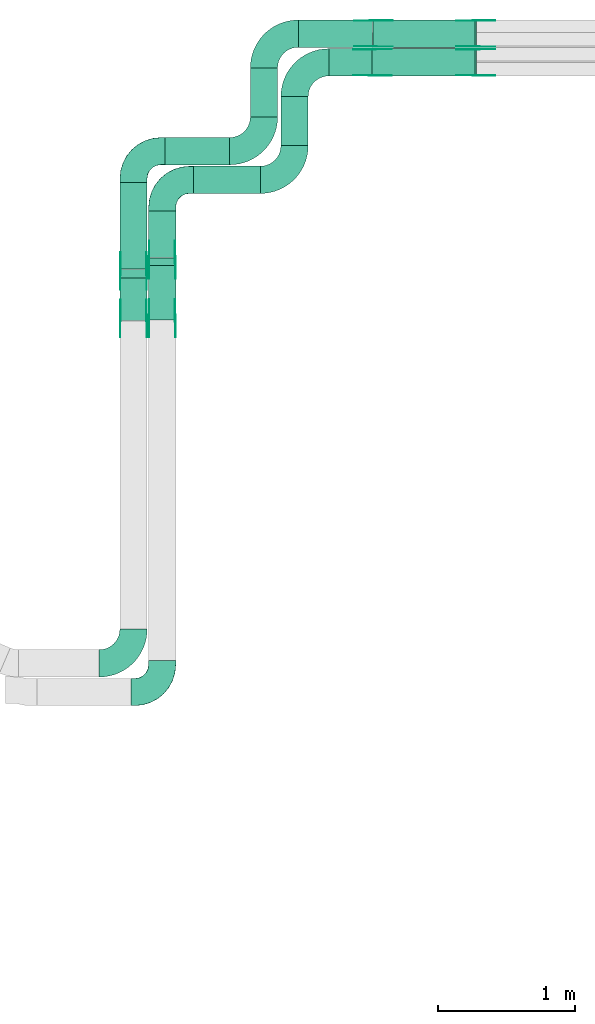
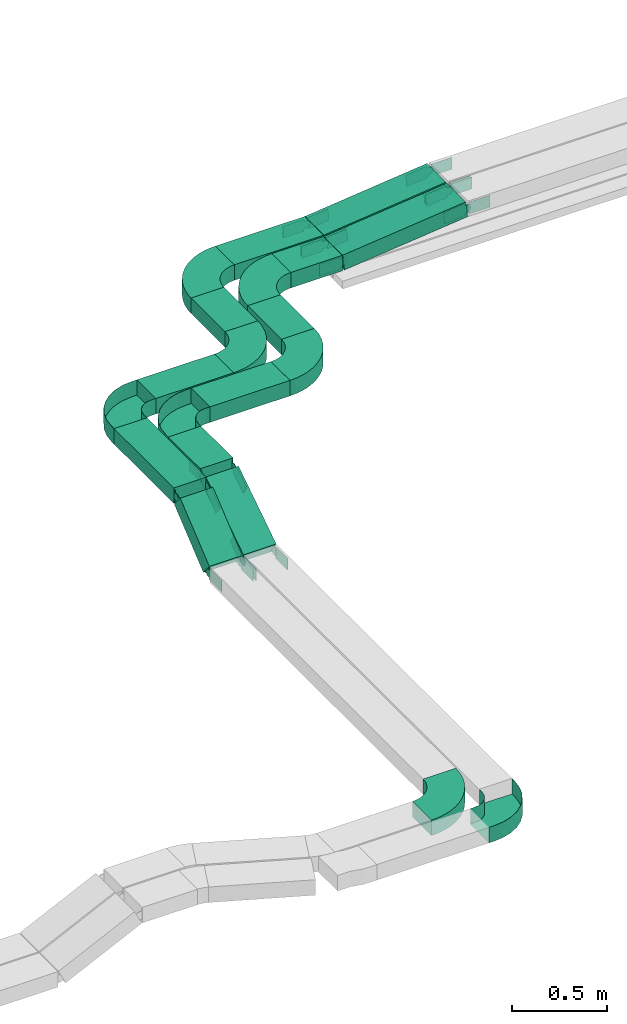
# One storey, part 16 of 25: 40 flow fittings, 12 flow segments.
"""IFC2X3 building model written with IfcOpenShell, lengths in millimetres."""

from ifc_helpers import new_model, entity, si_unit, converted_unit, derived_unit, direction, frame, frame_2d, origin, origin_2d_with_axis, place, context, subcontext, project, spatial, polyline, circle_curve, parameter, trimmed, segment, composite_curve, rectangle, outline, extrude, faceted_brep, source, transform, mapped, material, type_object, type_shapes, element, save


model = new_model("IFC2X3")

# Units and contexts
model_context = context("Model", 3, precision=0.01, world=origin(), true_north=direction((6.12303176911189e-17, 1.0)))
body_context = subcontext(model_context, "Body", "Model", "MODEL_VIEW")
ifc_project = project(units=[si_unit("LENGTHUNIT", "METRE", prefix="MILLI"), si_unit("AREAUNIT", "SQUARE_METRE"), si_unit("VOLUMEUNIT", "CUBIC_METRE"), converted_unit("PLANEANGLEUNIT", "DEGREE", entity("IfcRatioMeasure", 0.0174532925199433), si_unit("PLANEANGLEUNIT", "RADIAN"), dimensions=[0, 0, 0, 0, 0, 0, 0]), si_unit("MASSUNIT", "GRAM", prefix="KILO"), derived_unit("MASSDENSITYUNIT", [(si_unit("MASSUNIT", "GRAM", prefix="KILO"), 1), (si_unit("LENGTHUNIT", "METRE"), -3)]), derived_unit("MOMENTOFINERTIAUNIT", [(si_unit("LENGTHUNIT", "METRE"), 4)]), si_unit("TIMEUNIT", "SECOND"), si_unit("FREQUENCYUNIT", "HERTZ"), si_unit("THERMODYNAMICTEMPERATUREUNIT", "DEGREE_CELSIUS"), derived_unit("THERMALTRANSMITTANCEUNIT", [(si_unit("MASSUNIT", "GRAM", prefix="KILO"), 1), (si_unit("THERMODYNAMICTEMPERATUREUNIT", "KELVIN"), -1), (si_unit("TIMEUNIT", "SECOND"), -3)]), derived_unit("VOLUMETRICFLOWRATEUNIT", [(si_unit("LENGTHUNIT", "METRE"), 3), (si_unit("TIMEUNIT", "SECOND"), -1)]), derived_unit("MASSFLOWRATEUNIT", [(si_unit("MASSUNIT", "GRAM", prefix="KILO"), 1), (si_unit("TIMEUNIT", "SECOND"), -1)]), derived_unit("ROTATIONALFREQUENCYUNIT", [(si_unit("TIMEUNIT", "SECOND"), -1)]), si_unit("ELECTRICCURRENTUNIT", "AMPERE"), si_unit("ELECTRICVOLTAGEUNIT", "VOLT"), si_unit("POWERUNIT", "WATT"), si_unit("FORCEUNIT", "NEWTON", prefix="KILO"), si_unit("ILLUMINANCEUNIT", "LUX"), si_unit("LUMINOUSFLUXUNIT", "LUMEN"), si_unit("LUMINOUSINTENSITYUNIT", "CANDELA"), derived_unit("USERDEFINED", [(si_unit("MASSUNIT", "GRAM", prefix="KILO"), -1), (si_unit("LENGTHUNIT", "METRE"), -2), (si_unit("TIMEUNIT", "SECOND"), 3), (si_unit("LUMINOUSFLUXUNIT", "LUMEN"), 1)]), derived_unit("LINEARVELOCITYUNIT", [(si_unit("LENGTHUNIT", "METRE"), 1), (si_unit("TIMEUNIT", "SECOND"), -1)]), si_unit("PRESSUREUNIT", "PASCAL"), derived_unit("USERDEFINED", [(si_unit("LENGTHUNIT", "METRE"), -2), (si_unit("MASSUNIT", "GRAM", prefix="KILO"), 1), (si_unit("TIMEUNIT", "SECOND"), -2)]), derived_unit("LINEARFORCEUNIT", [(si_unit("MASSUNIT", "GRAM", prefix="KILO"), 1), (si_unit("LENGTHUNIT", "METRE"), 1), (si_unit("TIMEUNIT", "SECOND"), -2), (si_unit("LENGTHUNIT", "METRE"), -1)]), derived_unit("PLANARFORCEUNIT", [(si_unit("MASSUNIT", "GRAM", prefix="KILO"), 1), (si_unit("LENGTHUNIT", "METRE"), 1), (si_unit("TIMEUNIT", "SECOND"), -2), (si_unit("LENGTHUNIT", "METRE"), -2)])], contexts=[model_context])

# Site, building, storey
site_placement = place(None, frame((0.0, -0.00077364408347762, 0.0)))
site = spatial("IfcSite", under=ifc_project, at=site_placement, CompositionType="ELEMENT")
building_placement = place(site_placement, origin())
building = spatial("IfcBuilding", under=site, at=building_placement, CompositionType="ELEMENT")
storey_placement = place(building_placement, frame((0.0, 0.0, 24000.0)))
storey = spatial("IfcBuildingStorey", under=building, at=storey_placement, CompositionType="ELEMENT", Elevation=24000.0)

# Flow segments
cable_carrier_segment_type = type_object("IfcCableCarrierSegmentType", PredefinedType="CABLETRAYSEGMENT")
flow_segment_1_placement = place(storey_placement, frame((40330.6005282686, 17371.8034156188, 3163.62105725894)))
element("IfcFlowSegment", 1, at=flow_segment_1_placement, inside=storey, type_object=cable_carrier_segment_type, context=body_context, shape_type="SweptSolid", body=[
    extrude(rectangle(XDim=338.196584381319, YDim=200.000000000007, at=frame_2d((-1.08002495835535e-12, 4.33431068813661e-12), x_axis=(1.0, 0.0))), frame((100.0, 169.098292190666, 0.0), z_axis=(0.0, 0.0, 1.0), x_axis=(0.0, 1.0, 0.0)), (0.0, 0.0, 1.0), 99.9999999999989),
])
flow_segment_2_placement = place(storey_placement, frame((40120.6005282686, 17287.9524673424, 3163.62105725894)))
element("IfcFlowSegment", 2, at=flow_segment_2_placement, inside=storey, type_object=cable_carrier_segment_type, context=body_context, shape_type="SweptSolid", body=[
    extrude(rectangle(XDim=632.047532657661, YDim=200.000000000007, at=frame_2d((1.08002495835535e-12, 4.33431068813661e-12), x_axis=(1.0, 0.0))), frame((100.0, 316.023766328833, 0.0), z_axis=(0.0, 0.0, 1.0), x_axis=(0.0, -1.0, 0.0)), (0.0, 0.0, 1.0), 100.000000000003),
])
flow_segment_3_placement = place(storey_placement, frame((40660.6005282686, 17840.0, 3163.62105725894)))
element("IfcFlowSegment", 3, at=flow_segment_3_placement, inside=storey, type_object=cable_carrier_segment_type, context=body_context, shape_type="SweptSolid", body=[
    extrude(rectangle(XDim=487.927271502945, YDim=200.000000000002, at=frame_2d((0.0, -2.16715534406831e-12), x_axis=(1.0, 0.0))), frame((243.963635751473, 100.0, 0.0)), (0.0, 0.0, 1.0), 100.000000000003),
])
flow_segment_4_placement = place(storey_placement, frame((40450.6005282686, 18050.0, 3163.62105725894)))
element("IfcFlowSegment", 4, at=flow_segment_4_placement, inside=storey, type_object=cable_carrier_segment_type, context=body_context, shape_type="SweptSolid", body=[
    extrude(rectangle(XDim=474.11608127522, YDim=200.000000000002, at=frame_2d((-4.33431068813661e-12, 2.16715534406831e-12), x_axis=(1.0, 0.0))), frame((237.058040637606, 100.0, 0.0)), (0.0, 0.0, 1.0), 100.000000000003),
])
flow_segment_5_placement = place(storey_placement, frame((40120.6005282686, 16911.7546448792, 2908.00071873042)))
element("IfcFlowSegment", 5, at=flow_segment_5_placement, inside=storey, type_object=cable_carrier_segment_type, context=body_context, shape_type="SweptSolid", body=[
    extrude(rectangle(XDim=100.000000000003, YDim=399.48780758858, at=frame_2d((0.0, 0.0), x_axis=(0.0, 1.0))), frame((0.0, 185.941079094469, 165.620338528534), z_axis=(1.0, 0.0, 0.0), x_axis=(0.0, 0.771695487741885, 0.63599219664931)), (0.0, 0.0, 1.0), 200.000000000006),
])
flow_segment_6_placement = place(storey_placement, frame((40330.6005282686, 16914.7229223301, 2901.20938168854)))
element("IfcFlowSegment", 6, at=flow_segment_6_placement, inside=storey, type_object=cable_carrier_segment_type, context=body_context, shape_type="SweptSolid", body=[
    extrude(rectangle(XDim=99.9999999999991, YDim=476.228564932628, at=frame_2d((-1.19371179607697e-12, -1.81188397618826e-12), x_axis=(0.0, 1.0))), frame((0.0, 226.525183876411, 172.411675570395), z_axis=(1.0, 0.0, 0.0), x_axis=(0.0, 0.836155462391767, 0.548492518374144)), (0.0, 0.0, 1.0), 200.000000000006),
])
flow_segment_7_placement = place(storey_placement, frame((41299.5277997716, 18191.0, 3163.62105725894)))
element("IfcFlowSegment", 7, at=flow_segment_7_placement, inside=storey, type_object=cable_carrier_segment_type, context=body_context, shape_type="SweptSolid", body=[
    extrude(rectangle(XDim=358.000000000016, YDim=200.000000000007, at=origin_2d_with_axis()), frame((100.0, 179.0, 0.0), z_axis=(0.0, 0.0, 1.0), x_axis=(0.0, 1.0, 0.0)), (0.0, 0.0, 1.0), 100.000000000003),
])
flow_segment_8_placement = place(storey_placement, frame((41075.7166095438, 18401.0, 3163.62105725894)))
element("IfcFlowSegment", 8, at=flow_segment_8_placement, inside=storey, type_object=cable_carrier_segment_type, context=body_context, shape_type="SweptSolid", body=[
    extrude(rectangle(XDim=358.000000000023, YDim=200.000000000007, at=frame_2d((-1.08002495835535e-12, 4.33431068813661e-12), x_axis=(1.0, 0.0))), frame((100.0, 179.0, 0.0), z_axis=(0.0, 0.0, 1.0), x_axis=(0.0, 1.0, 0.0)), (0.0, 0.0, 1.0), 100.000000000003),
])
flow_segment_9_placement = place(storey_placement, frame((41650.5277997715, 18700.0, 3163.62105725892)))
element("IfcFlowSegment", 9, at=flow_segment_9_placement, inside=storey, type_object=cable_carrier_segment_type, context=body_context, shape_type="SweptSolid", body=[
    extrude(rectangle(XDim=314.053975483834, YDim=199.999999999998, at=origin_2d_with_axis()), frame((157.026987741926, 100.0, 0.0)), (0.0, 0.0, 1.0), 100.000000000003),
])
flow_segment_10_placement = place(storey_placement, frame((41426.7166095438, 18910.0, 3163.62105725892)))
element("IfcFlowSegment", 10, at=flow_segment_10_placement, inside=storey, type_object=cable_carrier_segment_type, context=body_context, shape_type="SweptSolid", body=[
    extrude(rectangle(XDim=545.075260830746, YDim=200.000000000002, at=frame_2d((-4.34852154285181e-12, 0.0), x_axis=(1.0, 0.0))), frame((272.537630415378, 100.0, 0.0)), (0.0, 0.0, 1.0), 100.000000000003),
])
flow_segment_11_placement = place(storey_placement, frame((41967.0039956311, 18700.0, 3164.32499807541)))
element("IfcFlowSegment", 11, at=flow_segment_11_placement, inside=storey, type_object=cable_carrier_segment_type, context=body_context, shape_type="SweptSolid", body=[
    extrude(rectangle(XDim=99.9999999999953, YDim=199.999999999998, at=origin_2d_with_axis()), frame((5.3495035837806, 100.0, 49.7130044496137), z_axis=(0.994260088992235, 0.0, 0.106990071675617), x_axis=(-0.106990071675617, 0.0, 0.994260088992235)), (0.0, 0.0, 1.0), 756.593423660449),
])
flow_segment_12_placement = place(storey_placement, frame((41974.2180478637, 18910.0, 3164.33744833758)))
element("IfcFlowSegment", 12, at=flow_segment_12_placement, inside=storey, type_object=cable_carrier_segment_type, context=body_context, shape_type="SweptSolid", body=[
    extrude(rectangle(XDim=100.0, YDim=200.000000000002, at=frame_2d((-4.30588897870621e-12, 0.0), x_axis=(1.0, 0.0))), frame((5.40034172004957, 100.0, 49.7075075748849), z_axis=(0.994150151497607, 0.0, 0.108006834400818), x_axis=(-0.108006834400818, 0.0, 0.994150151497607)), (0.0, 0.0, 1.0), 749.342190250516),
])

# Flow fittings
ifc_material_1 = material(Name="G")
cable_carrier_fitting_type_1 = type_object("IfcCableCarrierFittingType", PredefinedType="NOTDEFINED", material=ifc_material_1)
shared_shape_1 = source(origin(), body_context, "Body", "SweptSolid", [
    extrude(outline(composite_curve([segment(trimmed(circle_curve(frame_2d((-41.4651162790697, 0.0), x_axis=(1.0, 0.0)), 25.0), [parameter(90.0000000000007)], [parameter(270.0)], True, "PARAMETER"), True, "CONTINUOUS"), segment(polyline([(-41.4651162790697, -25.0), (-29.9651162790697, -25.0)]), True, "CONTINUOUS"), segment(polyline([(-29.9651162790697, -25.0), (-28.1046511627907, -38.5)]), True, "CONTINUOUS"), segment(polyline([(-28.1046511627907, -38.5), (99.5348837209303, -38.5)]), True, "CONTINUOUS"), segment(polyline([(99.5348837209303, -38.5), (99.5348837209303, 38.5)]), True, "CONTINUOUS"), segment(polyline([(99.5348837209303, 38.5), (-28.1046511627907, 38.5)]), True, "CONTINUOUS"), segment(polyline([(-28.1046511627907, 38.5), (-29.9651162790697, 25.0)]), True, "CONTINUOUS"), segment(polyline([(-29.9651162790697, 25.0), (-41.46511627907, 25.0)]), True, "CONTINUOUS")], self_intersect=False)), frame((41.4651162790697, 0.0, 0.0), z_axis=(0.0, 0.0, -1.0), x_axis=(1.0, 0.0, 0.0)), (0.0, 0.0, -1.0), 2.0),
])
type_shapes(cable_carrier_fitting_type_1, [shared_shape_1])
for number, where, z_axis, x_axis in (
    (13, (40526.0605282788, 17354.6726485901, 3213.62105725897), (1.0, 0.0, 0.0), (0.0, -0.836155462391787, -0.548492518374114)),
    (14, (40316.0605282788, 17267.5678841245, 3213.621057259), (1.0, 0.0, 0.0), (0.0, -0.771695487741913, -0.635992196649276)),
    (15, (40125.1405282585, 16927.8235638228, 2933.62105725888), (-1.0, 0.0, 0.0), (0.0, -1.0, 0.0)),
    (16, (40335.1405282585, 16927.8235638228, 2933.62105725887), (-1.0, 0.0, 0.0), (0.0, -1.0, 0.0)),
    (17, (41968.4788215847, 18704.5399999899, 3213.62105725891), (0.0, -1.0, 0.0), (0.994260088992224, 0.0, 0.106990071675716)),
    (18, (41975.7166095439, 18914.5399999899, 3213.62105725891), (0.0, -1.0, 0.0), (0.994150151497606, 0.0, 0.108006834400827)),
    (19, (42728.4788215847, 18895.4600000103, 3295.40293241793), (0.0, 1.0, 0.0), (1.0, 0.0, 0.0)),
    (20, (42728.4788215847, 19105.4600000103, 3295.40293241794), (0.0, 1.0, 0.0), (1.0, 0.0, 0.0)),
):
    element("IfcFlowFitting", number, at=place(storey_placement, frame(where, z_axis=z_axis, x_axis=x_axis)), inside=storey, type_object=cable_carrier_fitting_type_1, material=ifc_material_1, context=body_context, shape_type="MappedRepresentation", body=[
        mapped(shared_shape_1, transform((0.0, 0.0, 0.0), scale=1.0)),
    ])
cable_carrier_fitting_type_2 = type_object("IfcCableCarrierFittingType", PredefinedType="NOTDEFINED", material=ifc_material_1)
shared_shape_2 = source(origin(), body_context, "Body", "SweptSolid", [
    extrude(outline(composite_curve([segment(trimmed(circle_curve(frame_2d((-41.4651162790697, 0.0), x_axis=(1.0, 0.0)), 25.0), [parameter(90.0000000000007)], [parameter(270.0)], True, "PARAMETER"), True, "CONTINUOUS"), segment(polyline([(-41.4651162790697, -25.0), (-29.9651162790697, -25.0)]), True, "CONTINUOUS"), segment(polyline([(-29.9651162790697, -25.0), (-28.1046511627907, -38.5)]), True, "CONTINUOUS"), segment(polyline([(-28.1046511627907, -38.5), (99.5348837209303, -38.5)]), True, "CONTINUOUS"), segment(polyline([(99.5348837209303, -38.5), (99.5348837209303, 38.5)]), True, "CONTINUOUS"), segment(polyline([(99.5348837209303, 38.5), (-28.1046511627907, 38.5)]), True, "CONTINUOUS"), segment(polyline([(-28.1046511627907, 38.5), (-29.9651162790697, 25.0)]), True, "CONTINUOUS"), segment(polyline([(-29.9651162790697, 25.0), (-41.46511627907, 25.0)]), True, "CONTINUOUS")], self_intersect=False)), frame((41.4651162790697, 0.0, 0.0)), (0.0, 0.0, 1.0), 2.0),
])
type_shapes(cable_carrier_fitting_type_2, [shared_shape_2])
for number, where, z_axis, x_axis in (
    (21, (40335.1405282585, 17354.6726485901, 3213.62105725897), (-1.0, 0.0, 0.0), (0.0, -0.836155462391787, -0.548492518374114)),
    (22, (40125.1405282585, 17267.5678841245, 3213.621057259), (-1.0, 0.0, 0.0), (0.0, -0.771695487741913, -0.635992196649276)),
    (23, (40316.0605282788, 16927.8235638228, 2933.62105725888), (1.0, 0.0, 0.0), (0.0, -1.0, 0.0)),
    (24, (40526.0605282788, 16927.8235638228, 2933.62105725887), (1.0, 0.0, 0.0), (0.0, -1.0, 0.0)),
    (25, (41968.4788215847, 18895.4600000103, 3213.62105725891), (0.0, 1.0, 0.0), (0.994260088992224, 0.0, 0.106990071675716)),
    (26, (41975.7166095439, 19105.4600000103, 3213.62105725891), (0.0, 1.0, 0.0), (0.994150151497606, 0.0, 0.108006834400827)),
    (27, (42728.4788215847, 18704.5399999899, 3295.40293241793), (0.0, -1.0, 0.0), (1.0, 0.0, 0.0)),
    (28, (42728.4788215847, 18914.5399999899, 3295.40293241794), (0.0, -1.0, 0.0), (1.0, 0.0, 0.0)),
):
    element("IfcFlowFitting", number, at=place(storey_placement, frame(where, z_axis=z_axis, x_axis=x_axis)), inside=storey, type_object=cable_carrier_fitting_type_2, material=ifc_material_1, context=body_context, shape_type="MappedRepresentation", body=[
        mapped(shared_shape_2, transform((0.0, 0.0, 0.0), scale=1.0)),
    ])
cable_carrier_fitting_type_3 = type_object("IfcCableCarrierFittingType", PredefinedType="NOTDEFINED", material=ifc_material_1)
shared_shape_3 = source(origin(), body_context, "Body", "SweptSolid", [
    extrude(outline(composite_curve([segment(trimmed(circle_curve(frame_2d((-41.4651162790697, 0.0), x_axis=(1.0, 0.0)), 25.0), [parameter(90.0000000000007)], [parameter(270.0)], True, "PARAMETER"), True, "CONTINUOUS"), segment(polyline([(-41.4651162790697, -25.0), (-29.9651162790697, -25.0)]), True, "CONTINUOUS"), segment(polyline([(-29.9651162790697, -25.0), (-28.1046511627907, -38.5)]), True, "CONTINUOUS"), segment(polyline([(-28.1046511627907, -38.5), (99.5348837209303, -38.5)]), True, "CONTINUOUS"), segment(polyline([(99.5348837209303, -38.5), (99.5348837209303, 38.5)]), True, "CONTINUOUS"), segment(polyline([(99.5348837209303, 38.5), (-28.1046511627907, 38.5)]), True, "CONTINUOUS"), segment(polyline([(-28.1046511627907, 38.5), (-29.9651162790697, 25.0)]), True, "CONTINUOUS"), segment(polyline([(-29.9651162790697, 25.0), (-41.46511627907, 25.0)]), True, "CONTINUOUS")], self_intersect=False)), frame((41.4651162790697, 0.0, 0.0), z_axis=(0.0, 0.0, -1.0), x_axis=(1.0, 0.0, 0.0)), (0.0, 0.0, -1.0), 2.0),
])
type_shapes(cable_carrier_fitting_type_3, [shared_shape_3])
for number, where, z_axis, x_axis in (
    (29, (40337.1405282585, 17354.6726485901, 3213.62105725897), (-1.0, 0.0, 0.0), (0.0, 1.0, 0.0)),
    (30, (40127.1405282585, 17267.5678841244, 3213.621057259), (-1.0, 0.0, 0.0), (0.0, 1.0, 0.0)),
    (31, (40314.0605282788, 16927.8235638228, 2933.62105725888), (1.0, 0.0, 0.0), (0.0, 0.771695487741889, 0.635992196649305)),
    (32, (40524.0605282788, 16927.8235638228, 2933.62105725887), (1.0, 0.0, 0.0), (0.0, 0.83615546239177, 0.548492518374139)),
    (33, (41968.4788215847, 18893.4600000103, 3213.62105725891), (0.0, 1.0, 0.0), (-1.0, 0.0, 0.0)),
    (34, (41975.7166095439, 19103.4600000103, 3213.62105725891), (0.0, 1.0, 0.0), (-1.0, 0.0, 0.0)),
    (35, (42728.4788215847, 18706.5399999899, 3295.40293241793), (0.0, -1.0, 0.0), (-0.994260088992227, 0.0, -0.106990071675685)),
    (36, (42728.4788215847, 18916.5399999899, 3295.40293241794), (0.0, -1.0, 0.0), (-0.99415015149761, 0.0, -0.10800683440079)),
):
    element("IfcFlowFitting", number, at=place(storey_placement, frame(where, z_axis=z_axis, x_axis=x_axis)), inside=storey, type_object=cable_carrier_fitting_type_3, material=ifc_material_1, context=body_context, shape_type="MappedRepresentation", body=[
        mapped(shared_shape_3, transform((0.0, 0.0, 0.0), scale=1.0)),
    ])
cable_carrier_fitting_type_4 = type_object("IfcCableCarrierFittingType", PredefinedType="NOTDEFINED", material=ifc_material_1)
shared_shape_4 = source(origin(), body_context, "Body", "SweptSolid", [
    extrude(outline(composite_curve([segment(trimmed(circle_curve(frame_2d((-41.4651162790697, 0.0), x_axis=(1.0, 0.0)), 25.0), [parameter(90.0000000000007)], [parameter(270.0)], True, "PARAMETER"), True, "CONTINUOUS"), segment(polyline([(-41.4651162790697, -25.0), (-29.9651162790697, -25.0)]), True, "CONTINUOUS"), segment(polyline([(-29.9651162790697, -25.0), (-28.1046511627907, -38.5)]), True, "CONTINUOUS"), segment(polyline([(-28.1046511627907, -38.5), (99.5348837209303, -38.5)]), True, "CONTINUOUS"), segment(polyline([(99.5348837209303, -38.5), (99.5348837209303, 38.5)]), True, "CONTINUOUS"), segment(polyline([(99.5348837209303, 38.5), (-28.1046511627907, 38.5)]), True, "CONTINUOUS"), segment(polyline([(-28.1046511627907, 38.5), (-29.9651162790697, 25.0)]), True, "CONTINUOUS"), segment(polyline([(-29.9651162790697, 25.0), (-41.46511627907, 25.0)]), True, "CONTINUOUS")], self_intersect=False)), frame((41.4651162790697, 0.0, 0.0)), (0.0, 0.0, 1.0), 2.0),
])
type_shapes(cable_carrier_fitting_type_4, [shared_shape_4])
for number, where, z_axis, x_axis in (
    (37, (40524.0605282788, 17354.6726485901, 3213.62105725896), (1.0, 0.0, 0.0), (0.0, 1.0, 0.0)),
    (38, (40314.0605282788, 17267.5678841244, 3213.62105725899), (1.0, 0.0, 0.0), (0.0, 1.0, 0.0)),
    (39, (40127.1405282585, 16927.8235638228, 2933.62105725888), (-1.0, 0.0, 0.0), (0.0, 0.771695487741889, 0.635992196649305)),
    (40, (40337.1405282585, 16927.8235638228, 2933.62105725887), (-1.0, 0.0, 0.0), (0.0, 0.83615546239177, 0.548492518374139)),
    (41, (41968.4788215847, 18706.5399999899, 3213.62105725892), (0.0, -1.0, 0.0), (-1.0, 0.0, 0.0)),
    (42, (41975.7166095439, 18916.5399999899, 3213.62105725892), (0.0, -1.0, 0.0), (-1.0, 0.0, 0.0)),
    (43, (42728.4788215847, 18893.4600000103, 3295.40293241793), (0.0, 1.0, 0.0), (-0.994260088992227, 0.0, -0.106990071675685)),
    (44, (42728.4788215847, 19103.4600000103, 3295.40293241793), (0.0, 1.0, 0.0), (-0.99415015149761, 0.0, -0.10800683440079)),
):
    element("IfcFlowFitting", number, at=place(storey_placement, frame(where, z_axis=z_axis, x_axis=x_axis)), inside=storey, type_object=cable_carrier_fitting_type_4, material=ifc_material_1, context=body_context, shape_type="MappedRepresentation", body=[
        mapped(shared_shape_4, transform((0.0, 0.0, 0.0), scale=1.0)),
    ])
ifc_material_2 = material()
cable_carrier_fitting_type_5 = type_object("IfcCableCarrierFittingType", Name="470_DKC_S5_Variable Angle Elbow 0-45:-", PredefinedType="NOTDEFINED", material=ifc_material_2)
shared_shape_5 = source(origin(), body_context, "Body", "SweptSolid", [
    extrude(outline(composite_curve([segment(polyline([(-125.750000000001, -225.25), (-124.749999999999, -225.25)]), True, "CONTINUOUS"), segment(trimmed(circle_curve(frame_2d((-124.75, 124.75), x_axis=(0.0, -1.0)), 350.0), [parameter(0.0)], [parameter(90.0000000000001)], True, "PARAMETER"), True, "CONTINUOUS"), segment(polyline([(225.25, 124.75), (225.25, 125.749999999999)]), True, "CONTINUOUS"), segment(polyline([(225.25, 125.749999999999), (25.25, 125.750000000001)]), True, "CONTINUOUS"), segment(polyline([(25.25, 125.750000000001), (25.25, 124.75)]), True, "CONTINUOUS"), segment(trimmed(circle_curve(frame_2d((-124.75, 124.75), x_axis=(0.0, -1.0)), 150.0), [parameter(0.0)], [parameter(90.0000000000001)], True, "PARAMETER"), False, "CONTINUOUS"), segment(polyline([(-124.749999999999, -25.2500000000003), (-125.750000000001, -25.2500000000003)]), True, "CONTINUOUS"), segment(polyline([(-125.750000000001, -25.2500000000003), (-125.750000000001, -225.25)]), True, "CONTINUOUS")], self_intersect=False)), frame((-125.249999999991, 125.249999999992, -50.0)), (0.0, 0.0, 1.0), 100.0),
])
type_shapes(cable_carrier_fitting_type_5, [shared_shape_5])
for number, where, name in (
    (45, (41399.5277997716, 17940.0, 3213.62105725894), "470_DKC_S5_Variable Angle Elbow 0-45:-"),
    (46, (41175.7166095438, 18150.0, 3213.62105725894), "470_DKC_S5_Variable Angle Elbow 0-45:-"),
    (47, (40220.6005282686, 14400.3144759065, 2933.62105725895), "470_DKC_S5_Variable Angle Elbow 0-45:-"),
):
    element("IfcFlowFitting", number, at=place(storey_placement, frame(where)), inside=storey, type_object=cable_carrier_fitting_type_5, material=ifc_material_2, Name=name, ObjectType="470_DKC_S5_Variable Angle Elbow 0-45:-", context=body_context, shape_type="MappedRepresentation", body=[
        mapped(shared_shape_5, transform((0.0, 0.0, 0.0), scale=1.0)),
    ])
for number, where, z_axis, x_axis, name in (
    (48, (41399.5277997716, 18800.0, 3213.62105725894), (0.0, 0.0, 1.0), (-1.0, 0.0, 0.0), "470_DKC_S5_Variable Angle Elbow 0-45:-"),
    (49, (41175.7166095439, 19010.0, 3213.62105725894), (0.0, 0.0, 1.0), (-1.0, 0.0, 0.0), "470_DKC_S5_Variable Angle Elbow 0-45:-"),
):
    element("IfcFlowFitting", number, at=place(storey_placement, frame(where, z_axis=z_axis, x_axis=x_axis)), inside=storey, type_object=cable_carrier_fitting_type_5, material=ifc_material_2, Name=name, ObjectType="470_DKC_S5_Variable Angle Elbow 0-45:-", context=body_context, shape_type="MappedRepresentation", body=[
        mapped(shared_shape_5, transform((0.0, 0.0, 0.0), scale=1.0)),
    ])
cable_carrier_fitting_type_6 = type_object("IfcCableCarrierFittingType", Name="470_DKC_S5_CPO 45 horizontal angle:-", PredefinedType="NOTDEFINED", material=ifc_material_2)
shared_shape_6 = source(origin(), body_context, "Body", "Brep", [
    faceted_brep([(-230.0, -99.2000000000082, -49.2000000000019), (-230.0, 99.1999999999917, -49.2000000000019), (-230.0, 99.1999999999917, 50.0), (-230.0, 100.0, 50.0), (-230.0, 100.0, -50.0), (-230.0, -100.0, -50.0), (-230.0, -100.0, 50.0), (-230.0, -99.2000000000082, 50.0), (-200.0, -100.0, -50.0), (-200.0, -100.0, 50.0), (-141.472903395153, -94.2355841209775, 50.0), (-85.1949702904642, -77.1638597533945, 50.0), (-33.3289300941106, -49.4408836907721, 50.0), (12.132034355973, -12.1320343559729, 50.0), (49.4408836907724, 33.3289300941106, 50.0), (77.1638597533949, 85.1949702904643, 50.0), (94.2355841209781, 141.472903395153, 50.0), (100.0, 200.0, 50.0), (100.0, 230.0, 50.0), (99.2000000000087, 230.0, 50.0), (99.2000000000089, 200.0, 50.0), (93.4509558966552, 141.628975652766, 50.0), (76.4247561273856, 85.5011170363564, 50.0), (48.7757080009301, 33.7733862805264, 50.0), (11.5663489310236, -11.5663489310235, 50.0), (-33.7733862805263, -48.7757080009299, 50.0), (-85.5011170363564, -76.4247561273853, 50.0), (-141.628975652766, -93.4509558966548, 50.0), (-200.0, -99.2000000000082, 50.0), (-200.0, 99.1999999999917, 50.0), (-168.851086966996, 104.13350315744, 50.0), (-140.75124656891, 118.451086966997, 50.0), (-118.451086966997, 140.75124656891, 50.0), (-104.13350315744, 168.851086966997, 50.0), (-99.1999999999912, 200.0, 50.0), (-99.1999999999912, 230.0, 50.0), (-100.0, 230.0, 50.0), (-100.0, 200.0, 50.0), (-104.894348370476, 169.098300562497, 50.0), (-119.098300562496, 141.221474770744, 50.0), (-141.221474770744, 119.098300562497, 50.0), (-169.098300562496, 104.894348370476, 50.0), (-200.0, 100.0, 50.0), (-200.0, -99.2000000000082, -49.2000000000019), (-141.628975652766, -93.4509558966548, -49.2000000000019), (-85.5011170363564, -76.4247561273853, -49.2000000000019), (-33.7733862805263, -48.7757080009299, -49.2000000000019), (11.5663489310236, -11.5663489310235, -49.2000000000019), (48.7757080009301, 33.7733862805264, -49.2000000000019), (76.4247561273856, 85.5011170363564, -49.2000000000019), (93.4509558966552, 141.628975652766, -49.2000000000019), (99.2000000000087, 200.0, -49.2000000000019), (99.2000000000087, 230.0, -49.2000000000019), (-99.1999999999912, 230.0, -49.2000000000019), (-99.1999999999912, 200.0, -49.2000000000019), (-104.13350315744, 168.851086966997, -49.2000000000019), (-118.451086966997, 140.75124656891, -49.2000000000019), (-140.75124656891, 118.451086966997, -49.2000000000019), (-168.851086966996, 104.13350315744, -49.2000000000019), (-200.0, 99.1999999999917, -49.2000000000019), (-200.0, 100.0, -50.0), (-141.472903395153, -94.2355841209775, -50.0), (-169.098300562496, 104.894348370476, -50.0), (-141.221474770744, 119.098300562497, -50.0), (-119.098300562496, 141.221474770744, -50.0), (-104.894348370476, 169.098300562497, -50.0), (-100.0, 200.0, -50.0), (-100.0, 230.0, -50.0), (100.0, 230.0, -50.0), (100.0, 200.0, -50.0), (94.2355841209781, 141.472903395153, -50.0), (77.1638597533949, 85.1949702904643, -50.0), (49.4408836907724, 33.3289300941106, -50.0), (12.132034355973, -12.1320343559729, -50.0), (-33.3289300941106, -49.4408836907721, -50.0), (-85.1949702904642, -77.1638597533945, -50.0)], [[[0, 1, 2, 3, 4, 5, 6, 7]], [[6, 5, 8, 9]], [[7, 6, 9, 10, 11, 12, 13, 14, 15, 16, 17, 18, 19, 20, 21, 22, 23, 24, 25, 26, 27, 28]], [[3, 2, 29, 30, 31, 32, 33, 34, 35, 36, 37, 38, 39, 40, 41, 42]], [[0, 7, 28, 43]], [[1, 0, 43, 44, 45, 46, 47, 48, 49, 50, 51, 52, 53, 54, 55, 56, 57, 58, 59]], [[2, 1, 59, 29]], [[4, 3, 42, 60]], [[61, 8, 5, 4, 60, 62, 63, 64, 65, 66, 67, 68, 69, 70, 71, 72, 73, 74, 75]], [[10, 9, 8, 61]], [[61, 75, 11, 10]], [[74, 12, 11, 75]], [[73, 13, 12, 74]], [[14, 72, 71, 15]], [[15, 71, 70, 16]], [[16, 70, 69, 17]], [[73, 72, 14, 13]], [[44, 43, 28, 27]], [[26, 45, 44, 27]], [[45, 26, 25, 46]], [[25, 24, 47, 46]], [[49, 48, 23, 22]], [[50, 49, 22, 21]], [[51, 50, 21, 20]], [[24, 23, 48, 47]], [[58, 57, 31, 30]], [[59, 58, 30, 29]], [[57, 56, 32, 31]], [[32, 56, 55, 33]], [[33, 55, 54, 34]], [[41, 40, 63, 62]], [[41, 62, 60, 42]], [[40, 39, 64, 63]], [[65, 64, 39, 38]], [[66, 65, 38, 37]], [[67, 36, 35, 53, 52, 19, 18, 68]], [[17, 69, 68, 18]], [[51, 20, 19, 52]], [[34, 54, 53, 35]], [[66, 37, 36, 67]]]),
])
type_shapes(cable_carrier_fitting_type_6, [shared_shape_6])
for number, where, z_axis, x_axis, name in (
    (50, (40430.6005282686, 17940.0, 3213.62105725894), (0.0, 0.0, 1.0), (-1.0, 0.0, 0.0), "470_DKC_S5_45 horizontal angle"),
    (51, (40220.6005282687, 18150.0, 3213.62105725894), (0.0, 0.0, 1.0), (-1.0, 0.0, 0.0), "470_DKC_S5_45 horizontal angle"),
):
    element("IfcFlowFitting", number, at=place(storey_placement, frame(where, z_axis=z_axis, x_axis=x_axis)), inside=storey, type_object=cable_carrier_fitting_type_6, material=ifc_material_2, Name=name, ObjectType="470_DKC_S5_CPO 45 horizontal angle:-", context=body_context, shape_type="MappedRepresentation", body=[
        mapped(shared_shape_6, transform((0.0, 0.0, 0.0), scale=1.0)),
    ])
flow_fitting_placement = place(storey_placement, frame((40430.6005282686, 14190.3144759065, 2933.62105725889)))
element("IfcFlowFitting", 52, at=flow_fitting_placement, inside=storey, type_object=cable_carrier_fitting_type_6, material=ifc_material_2, Name="470_DKC_S5_45 horizontal angle", ObjectType="470_DKC_S5_CPO 45 horizontal angle:-", context=body_context, shape_type="MappedRepresentation", body=[
    mapped(shared_shape_6, transform((0.0, 0.0, 0.0), scale=1.0)),
])

save(model, "model.ifc")
